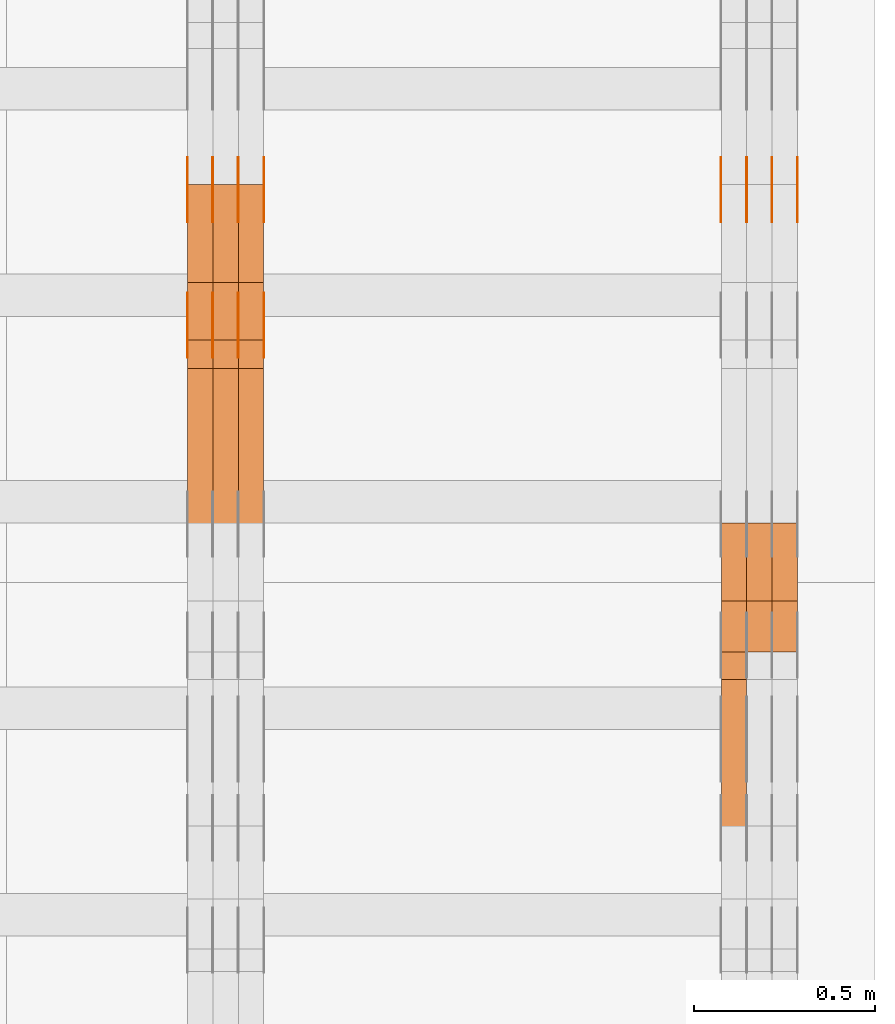
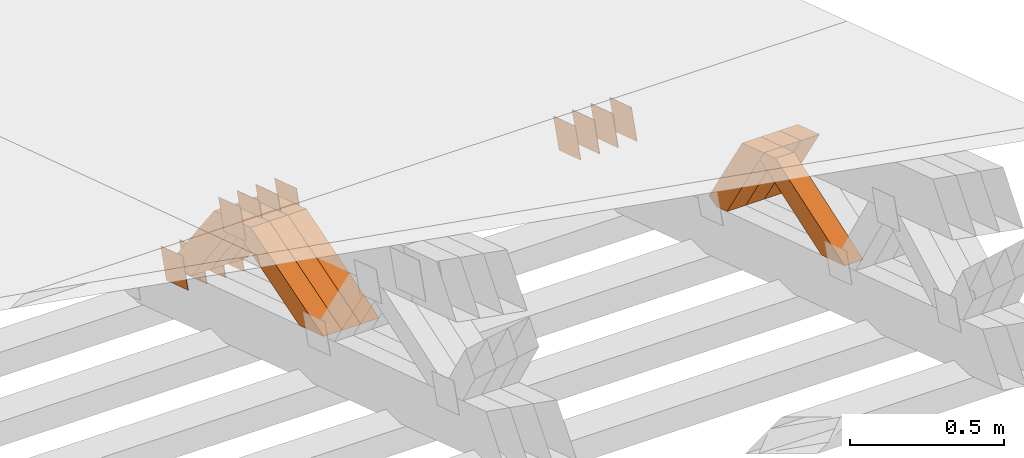
# One storey, part 368 of 385: 28 proxies.
"""IFC2X3 building model written with IfcOpenShell, lengths in millimetres."""

import ifcopenshell
import ifcopenshell.guid

model = None  # the IFC model being written
_history = None  # IfcOwnerHistory: only IFC2X3 demands one
_inside = {}  # id of a spatial element -> (the spatial element, [elements in it])
_under = {}  # id of a project, library or spatial element -> (it, [spatial elements below it])
_declared = {}  # id of a project -> (the project, [libraries it declares])
_typed = {}  # id of a type object -> (the type object, [elements of that type])
_made_of = {}  # id of a material, layer set ... -> (it, [elements and type objects made of it])


def new_model(schema):
    """Start an empty IFC model of exactly this schema.

    Asked for "IFC4X3", IfcOpenShell would pick the latest addendum, in which some entities
    have other attributes; the version numbers below select the first issue.
    IFC2X3 requires an IfcOwnerHistory on every rooted entity: one is made here for all.
    """
    global model, _history
    if schema == "IFC4X3":
        model = ifcopenshell.file(schema_version=(4, 3, 0, 0))
    else:
        model = ifcopenshell.file(schema=schema)
    _inside.clear()
    _under.clear()
    _declared.clear()
    _typed.clear()
    _made_of.clear()
    _history = None
    if model.schema == "IFC2X3":
        org = make("IfcOrganization", Name="unknown")
        user = make(
            "IfcPersonAndOrganization",
            ThePerson=make("IfcPerson", FamilyName="unknown"),
            TheOrganization=org,
        )
        app = make(
            "IfcApplication",
            ApplicationDeveloper=org,
            Version="unknown",
            ApplicationFullName="unknown",
            ApplicationIdentifier="unknown",
        )
        _history = make(
            "IfcOwnerHistory",
            OwningUser=user,
            OwningApplication=app,
            ChangeAction="ADDED",
            CreationDate=0,
        )
    return model


def make(cls, **values):
    """One entity of the class cls with the attributes given. An attribute that is None is left unset."""
    return model.create_entity(
        cls, **{name: value for name, value in values.items() if value is not None}
    )


def entity(cls, *values):
    """Any entity or typed value of the class cls, its attributes in the order of the schema. None: left unset."""
    e = model.create_entity(cls)
    for i, value in enumerate(values):
        if value is not None:
            e[i] = value
    return e


def rooted(cls, **values):
    """An entity with a GlobalId (a new one), such as an element, a storey or a relation."""
    return make(cls, GlobalId=ifcopenshell.guid.new(), OwnerHistory=_history, **values)


def si_unit(unit_type, name, prefix=None):
    """IfcSIUnit, for example si_unit("LENGTHUNIT", "METRE", prefix="MILLI")."""
    return make("IfcSIUnit", UnitType=unit_type, Prefix=prefix, Name=name)


def converted_unit(unit_type, name, factor, base, dimensions=None, offset=None):
    """IfcConversionBasedUnit, such as the inch: factor (a typed value) times the base unit."""
    return make(
        "IfcConversionBasedUnit"
        if offset is None
        else "IfcConversionBasedUnitWithOffset",
        ConversionOffset=offset,
        Dimensions=None
        if dimensions is None
        else entity("IfcDimensionalExponents", *dimensions),
        UnitType=unit_type,
        Name=name,
        ConversionFactor=make(
            "IfcMeasureWithUnit", ValueComponent=factor, UnitComponent=base
        ),
    )


def derived_unit(unit_type, elements):
    """IfcDerivedUnit: a product of units, each with its exponent."""
    return make(
        "IfcDerivedUnit",
        Elements=[
            make("IfcDerivedUnitElement", Unit=unit, Exponent=power)
            for unit, power in elements
        ],
        UnitType=unit_type,
    )


def assignment(units):
    """IfcUnitAssignment: the units of a project."""
    return None if units is None else make("IfcUnitAssignment", Units=units)


def point(xyz):
    """IfcCartesianPoint."""
    return None if xyz is None else make("IfcCartesianPoint", Coordinates=xyz)


def direction(xyz):
    """IfcDirection."""
    return None if xyz is None else make("IfcDirection", DirectionRatios=xyz)


def frame(location, z_axis=None, x_axis=None):
    """IfcAxis2Placement3D, a coordinate frame: its origin and axes. An axis left out is left unset."""
    return make(
        "IfcAxis2Placement3D",
        Location=point(location),
        Axis=direction(z_axis),
        RefDirection=direction(x_axis),
    )


def origin():
    """The frame at (0, 0, 0) with its axes left unset."""
    return frame((0.0, 0.0, 0.0))


def place(relative_to, where):
    """IfcLocalPlacement: puts the frame where relative to a parent placement (None: the world)."""
    return make(
        "IfcLocalPlacement", PlacementRelTo=relative_to, RelativePlacement=where
    )


def context(
    kind, dimensions, precision=None, world=None, true_north=None, identifier=None
):
    """IfcGeometricRepresentationContext, for example the 3D "Model" context."""
    return make(
        "IfcGeometricRepresentationContext",
        ContextIdentifier=identifier,
        ContextType=kind,
        CoordinateSpaceDimension=dimensions,
        Precision=precision,
        WorldCoordinateSystem=world,
        TrueNorth=true_north,
    )


def subcontext(parent, identifier, kind, view, scale=None):
    """IfcGeometricRepresentationSubContext, for example "Body" below "Model"."""
    return make(
        "IfcGeometricRepresentationSubContext",
        ContextIdentifier=identifier,
        ContextType=kind,
        ParentContext=parent,
        TargetScale=scale,
        TargetView=view,
    )


def project(units=None, contexts=None):
    """IfcProject with its units and contexts."""
    return rooted(
        "IfcProject",
        Name="project",
        RepresentationContexts=contexts,
        UnitsInContext=assignment(units),
    )


def spatial(cls, under=None, at=None, **own):
    """A site, building, storey or space (cls), placed at a placement, below another one or the project."""
    s = rooted(cls, ObjectPlacement=at, **own)
    if under is not None:
        _under.setdefault(under.id(), (under, []))[1].append(s)
    return s


def polyline(points):
    """IfcPolyline through the points."""
    return make("IfcPolyline", Points=[point(p) for p in points])


def outline(outer, holes=None, kind="AREA"):
    """IfcArbitraryClosedProfileDef: a profile drawn as a closed curve; with holes, ...WithVoids."""
    if holes is None:
        return make("IfcArbitraryClosedProfileDef", ProfileType=kind, OuterCurve=outer)
    return make(
        "IfcArbitraryProfileDefWithVoids",
        ProfileType=kind,
        OuterCurve=outer,
        InnerCurves=holes,
    )


def extrude(swept, where, along, depth):
    """IfcExtrudedAreaSolid: the profile swept, set in the frame where, extruded along a direction by depth."""
    return make(
        "IfcExtrudedAreaSolid",
        SweptArea=swept,
        Position=where,
        ExtrudedDirection=direction(along),
        Depth=depth,
    )


def shape(context_of_items, identifier, shape_type, items):
    """IfcShapeRepresentation: the items that make up one representation, for example the "Body"."""
    return make(
        "IfcShapeRepresentation",
        ContextOfItems=context_of_items,
        RepresentationIdentifier=identifier,
        RepresentationType=shape_type,
        Items=items,
    )


def source(mapping_origin, context_of_items, identifier, shape_type, items):
    """IfcRepresentationMap: a shape defined once, which mapped items show again and again."""
    return make(
        "IfcRepresentationMap",
        MappingOrigin=mapping_origin,
        MappedRepresentation=shape(context_of_items, identifier, shape_type, items),
    )


def transform(
    local_origin,
    x_axis=None,
    y_axis=None,
    z_axis=None,
    scale=None,
    scale2=None,
    scale3=None,
    uniform=True,
):
    """IfcCartesianTransformationOperator3D, or its non-uniform kind. x_axis, y_axis, z_axis: its Axis1, 2, 3."""
    if uniform:
        return make(
            "IfcCartesianTransformationOperator3D",
            Axis1=direction(x_axis),
            Axis2=direction(y_axis),
            LocalOrigin=point(local_origin),
            Scale=scale,
            Axis3=direction(z_axis),
        )
    return make(
        "IfcCartesianTransformationOperator3DnonUniform",
        Axis1=direction(x_axis),
        Axis2=direction(y_axis),
        LocalOrigin=point(local_origin),
        Scale=scale,
        Axis3=direction(z_axis),
        Scale2=scale2,
        Scale3=scale3,
    )


def mapped(mapping_source, mapping_target):
    """IfcMappedItem: shows the shape of a source again, moved by a transform."""
    return make(
        "IfcMappedItem", MappingSource=mapping_source, MappingTarget=mapping_target
    )


def material(Name=None, Category=None):
    """IfcMaterial."""
    return make("IfcMaterial", Name=Name, Category=Category)


def made_of(thing, what):
    """Note that an element or type object is made of a material, layer set ...; save() writes the relation."""
    if what is not None:
        _made_of.setdefault(what.id(), (what, []))[1].append(thing)
    return thing


def type_object(cls, material=None, **own):
    """A type object (cls), such as IfcWallType, which elements share."""
    return made_of(rooted(cls, **own), material)


def type_shapes(of_type, sources):
    """Give a type object the sources (RepresentationMaps) that its elements show as mapped items."""
    of_type.RepresentationMaps = sources


def element(
    cls,
    number,
    at=None,
    inside=None,
    cuts=None,
    type_object=None,
    material=None,
    context=None,
    identifier="Body",
    shape_type=None,
    held_by="IfcProductDefinitionShape",
    body=None,
    shapes=None,
    **own,
):
    """One element of the class cls, such as IfcWall. Its Tag is "e" and its number.

    at: its placement. inside: the storey or other place that contains it. cuts: it is an
    opening in that element (IfcRelVoidsElement). A single representation is given by context,
    identifier, shape_type and body (its items); several are given by shapes. held_by: the class
    of the entity that holds the representations. save() writes the other relations.
    """
    e = rooted(cls, Tag="e%d" % number, ObjectPlacement=at, **own)
    if body is not None:
        shapes = [shape(context, identifier, shape_type, body)]
    if shapes is not None:
        e.Representation = make(held_by, Representations=shapes)
    if inside is not None:
        _inside.setdefault(inside.id(), (inside, []))[1].append(e)
    if cuts is not None:
        rooted(
            "IfcRelVoidsElement", RelatingBuildingElement=cuts, RelatedOpeningElement=e
        )
    if type_object is not None:
        _typed.setdefault(type_object.id(), (type_object, []))[1].append(e)
    return made_of(e, material)


def aggregate(whole, parts):
    """IfcRelAggregates: a whole, such as a stair, and the parts it consists of."""
    return rooted("IfcRelAggregates", RelatingObject=whole, RelatedObjects=parts)


def save(model, path):
    """Write the relations noted so far, then the file.

    IfcRelAggregates (storeys below a building ...), IfcRelContainedInSpatialStructure (elements
    in a storey), IfcRelDefinesByType, IfcRelAssociatesMaterial and IfcRelDeclares: one each for
    every whole, place, type object, material and project.
    """
    for whole, parts in _under.values():
        aggregate(whole, parts)
    for where, things in _inside.values():
        rooted(
            "IfcRelContainedInSpatialStructure",
            RelatedElements=things,
            RelatingStructure=where,
        )
    for kind, things in _typed.values():
        rooted("IfcRelDefinesByType", RelatedObjects=things, RelatingType=kind)
    for what, things in _made_of.values():
        rooted("IfcRelAssociatesMaterial", RelatedObjects=things, RelatingMaterial=what)
    for by, libraries in _declared.values():
        rooted("IfcRelDeclares", RelatingContext=by, RelatedDefinitions=libraries)
    model.write(path)


model = new_model("IFC2X3")

# Units and contexts
model_context = context("Model", 3, precision=0.01, world=origin(), true_north=direction((6.12303176911189e-17, 1.0)))
body_context = subcontext(model_context, "Body", "Model", "MODEL_VIEW")
ifc_project = project(units=[si_unit("LENGTHUNIT", "METRE", prefix="MILLI"), si_unit("AREAUNIT", "SQUARE_METRE"), si_unit("VOLUMEUNIT", "CUBIC_METRE"), converted_unit("PLANEANGLEUNIT", "DEGREE", entity("IfcRatioMeasure", 0.0174532925199433), si_unit("PLANEANGLEUNIT", "RADIAN"), dimensions=[0, 0, 0, 0, 0, 0, 0]), si_unit("MASSUNIT", "GRAM", prefix="KILO"), derived_unit("MASSDENSITYUNIT", [(si_unit("MASSUNIT", "GRAM", prefix="KILO"), 1), (si_unit("LENGTHUNIT", "METRE"), -3)]), si_unit("TIMEUNIT", "SECOND"), si_unit("FREQUENCYUNIT", "HERTZ"), si_unit("THERMODYNAMICTEMPERATUREUNIT", "DEGREE_CELSIUS"), derived_unit("THERMALTRANSMITTANCEUNIT", [(si_unit("MASSUNIT", "GRAM", prefix="KILO"), 1), (si_unit("THERMODYNAMICTEMPERATUREUNIT", "KELVIN"), -1), (si_unit("TIMEUNIT", "SECOND"), -3)]), derived_unit("VOLUMETRICFLOWRATEUNIT", [(si_unit("LENGTHUNIT", "METRE"), 3), (si_unit("TIMEUNIT", "SECOND"), -1)]), si_unit("ELECTRICCURRENTUNIT", "AMPERE"), si_unit("ELECTRICVOLTAGEUNIT", "VOLT"), si_unit("POWERUNIT", "WATT"), si_unit("FORCEUNIT", "NEWTON", prefix="KILO"), si_unit("ILLUMINANCEUNIT", "LUX"), si_unit("LUMINOUSFLUXUNIT", "LUMEN"), si_unit("LUMINOUSINTENSITYUNIT", "CANDELA"), derived_unit("USERDEFINED", [(si_unit("MASSUNIT", "GRAM", prefix="KILO"), -1), (si_unit("LENGTHUNIT", "METRE"), -2), (si_unit("TIMEUNIT", "SECOND"), 3), (si_unit("LUMINOUSFLUXUNIT", "LUMEN"), 1)]), derived_unit("LINEARVELOCITYUNIT", [(si_unit("LENGTHUNIT", "METRE"), 1), (si_unit("TIMEUNIT", "SECOND"), -1)]), si_unit("PRESSUREUNIT", "PASCAL"), derived_unit("USERDEFINED", [(si_unit("LENGTHUNIT", "METRE"), -2), (si_unit("MASSUNIT", "GRAM", prefix="KILO"), 1), (si_unit("TIMEUNIT", "SECOND"), -2)])], contexts=[model_context])

# Site, building, storey
site_placement = place(None, origin())
site = spatial("IfcSite", under=ifc_project, at=site_placement, CompositionType="ELEMENT")
building_placement = place(site_placement, origin())
building = spatial("IfcBuilding", under=site, at=building_placement, CompositionType="ELEMENT")
storey_placement = place(building_placement, origin())
storey = spatial("IfcBuildingStorey", under=building, at=storey_placement, Name="Default", CompositionType="ELEMENT", Elevation=0.0)

# Proxies
ifc_material_1 = material(Name="IfcSurfaceStyle #616510")
building_element_proxy_type_1 = type_object("IfcBuildingElementProxyType", PredefinedType="NOTDEFINED", material=ifc_material_1)
shared_shape_1 = source(origin(), body_context, "Body", "SweptSolid", [
    extrude(outline(polyline([(-75.0001116115454, -60.0000599592451), (75.0000887592496, -60.0000599592451), (75.0001116115454, 60.0000599592451), (-75.0000887592496, 60.0000599592451), (-75.0001116115454, -60.0000599592451)])), frame((75.0001116115454, 60.0000599592451, 0.0), z_axis=(0.0, 0.0, 1.0), x_axis=(-1.0, 0.0, 0.0)), (0.0, 0.0, 1.0), 1.3),
])
type_shapes(building_element_proxy_type_1, [shared_shape_1])
proxy_1_placement = place(building_placement, frame((49861.3, 21881.0815195707, 1532.2522473242), z_axis=(-1.0, 0.0, 0.0), x_axis=(0.0, -0.951056516295124, 0.309016994375039)))
element("IfcBuildingElementProxy", 1, at=proxy_1_placement, inside=storey, type_object=building_element_proxy_type_1, material=ifc_material_1, context=body_context, shape_type="MappedRepresentation", body=[
    mapped(shared_shape_1, transform((0.0, 0.0, 0.0), scale=1.0)),
])
ifc_material_2 = material(Name="IfcSurfaceStyle #616453")
building_element_proxy_type_2 = type_object("IfcBuildingElementProxyType", PredefinedType="NOTDEFINED", material=ifc_material_2)
shared_shape_2 = source(origin(), body_context, "Body", "SweptSolid", [
    extrude(outline(polyline([(-75.0001116115454, -60.0000599592451), (75.0000887592496, -60.0000599592451), (75.0001116115454, 60.0000599592451), (-75.0000887592496, 60.0000599592451), (-75.0001116115454, -60.0000599592451)])), frame((75.0001116115454, 60.0000599592451, 0.0), z_axis=(0.0, 0.0, 1.0), x_axis=(-1.0, 0.0, 0.0)), (0.0, 0.0, 1.0), 1.3),
])
type_shapes(building_element_proxy_type_2, [shared_shape_2])
proxy_2_placement = place(building_placement, frame((49790.0, 21881.0815195707, 1532.2522473242), z_axis=(-1.0, 0.0, 0.0), x_axis=(0.0, -0.951056516295124, 0.309016994375039)))
element("IfcBuildingElementProxy", 2, at=proxy_2_placement, inside=storey, type_object=building_element_proxy_type_2, material=ifc_material_2, context=body_context, shape_type="MappedRepresentation", body=[
    mapped(shared_shape_2, transform((0.0, 0.0, 0.0), scale=1.0)),
])
ifc_material_3 = material(Name="IfcSurfaceStyle #616396")
building_element_proxy_type_3 = type_object("IfcBuildingElementProxyType", PredefinedType="NOTDEFINED", material=ifc_material_3)
shared_shape_3 = source(origin(), body_context, "Body", "SweptSolid", [
    extrude(outline(polyline([(-75.0001116115454, -60.0000599592451), (75.0000887592496, -60.0000599592451), (75.0001116115454, 60.0000599592451), (-75.0000887592496, 60.0000599592451), (-75.0001116115454, -60.0000599592451)])), frame((75.0001116115454, 60.0000599592451, 0.0), z_axis=(0.0, 0.0, 1.0), x_axis=(-1.0, 0.0, 0.0)), (0.0, 0.0, 1.0), 1.3),
])
type_shapes(building_element_proxy_type_3, [shared_shape_3])
proxy_3_placement = place(building_placement, frame((49791.3, 21881.0815195707, 1532.2522473242), z_axis=(-1.0, 0.0, 0.0), x_axis=(0.0, -0.951056516295124, 0.309016994375039)))
element("IfcBuildingElementProxy", 3, at=proxy_3_placement, inside=storey, type_object=building_element_proxy_type_3, material=ifc_material_3, context=body_context, shape_type="MappedRepresentation", body=[
    mapped(shared_shape_3, transform((0.0, 0.0, 0.0), scale=1.0)),
])
ifc_material_4 = material(Name="IfcSurfaceStyle #616339")
building_element_proxy_type_4 = type_object("IfcBuildingElementProxyType", PredefinedType="NOTDEFINED", material=ifc_material_4)
shared_shape_4 = source(origin(), body_context, "Body", "SweptSolid", [
    extrude(outline(polyline([(-75.0001116115454, -60.0000599592451), (75.0000887592496, -60.0000599592451), (75.0001116115454, 60.0000599592451), (-75.0000887592496, 60.0000599592451), (-75.0001116115454, -60.0000599592451)])), frame((75.0001116115454, 60.0000599592451, 0.0), z_axis=(0.0, 0.0, 1.0), x_axis=(-1.0, 0.0, 0.0)), (0.0, 0.0, 1.0), 1.29999999999999),
])
type_shapes(building_element_proxy_type_4, [shared_shape_4])
proxy_4_placement = place(building_placement, frame((49720.0, 21881.0815195707, 1532.2522473242), z_axis=(-1.0, 0.0, 0.0), x_axis=(0.0, -0.951056516295124, 0.309016994375039)))
element("IfcBuildingElementProxy", 4, at=proxy_4_placement, inside=storey, type_object=building_element_proxy_type_4, material=ifc_material_4, context=body_context, shape_type="MappedRepresentation", body=[
    mapped(shared_shape_4, transform((0.0, 0.0, 0.0), scale=1.0)),
])
ifc_material_5 = material(Name="IfcSurfaceStyle #616282")
building_element_proxy_type_5 = type_object("IfcBuildingElementProxyType", PredefinedType="NOTDEFINED", material=ifc_material_5)
shared_shape_5 = source(origin(), body_context, "Body", "SweptSolid", [
    extrude(outline(polyline([(-75.0001116115454, -60.0000599592451), (75.0000887592496, -60.0000599592451), (75.0001116115454, 60.0000599592451), (-75.0000887592496, 60.0000599592451), (-75.0001116115454, -60.0000599592451)])), frame((75.0001116115454, 60.0000599592451, 0.0), z_axis=(0.0, 0.0, 1.0), x_axis=(-1.0, 0.0, 0.0)), (0.0, 0.0, 1.0), 1.29999999999999),
])
type_shapes(building_element_proxy_type_5, [shared_shape_5])
proxy_5_placement = place(building_placement, frame((49721.3, 21881.0815195707, 1532.2522473242), z_axis=(-1.0, 0.0, 0.0), x_axis=(0.0, -0.951056516295124, 0.309016994375039)))
element("IfcBuildingElementProxy", 5, at=proxy_5_placement, inside=storey, type_object=building_element_proxy_type_5, material=ifc_material_5, context=body_context, shape_type="MappedRepresentation", body=[
    mapped(shared_shape_5, transform((0.0, 0.0, 0.0), scale=1.0)),
])
ifc_material_6 = material(Name="IfcSurfaceStyle #616225")
building_element_proxy_type_6 = type_object("IfcBuildingElementProxyType", PredefinedType="NOTDEFINED", material=ifc_material_6)
shared_shape_6 = source(origin(), body_context, "Body", "SweptSolid", [
    extrude(outline(polyline([(-75.0001116115454, -60.0000599592451), (75.0000887592496, -60.0000599592451), (75.0001116115454, 60.0000599592451), (-75.0000887592496, 60.0000599592451), (-75.0001116115454, -60.0000599592451)])), frame((75.0001116115454, 60.0000599592451, 0.0), z_axis=(0.0, 0.0, 1.0), x_axis=(-1.0, 0.0, 0.0)), (0.0, 0.0, 1.0), 1.29999999999999),
])
type_shapes(building_element_proxy_type_6, [shared_shape_6])
proxy_6_placement = place(building_placement, frame((49650.0, 21881.0815195707, 1532.2522473242), z_axis=(-1.0, 0.0, 0.0), x_axis=(0.0, -0.951056516295124, 0.309016994375039)))
element("IfcBuildingElementProxy", 6, at=proxy_6_placement, inside=storey, type_object=building_element_proxy_type_6, material=ifc_material_6, context=body_context, shape_type="MappedRepresentation", body=[
    mapped(shared_shape_6, transform((0.0, 0.0, 0.0), scale=1.0)),
])
ifc_material_7 = material(Name="IfcSurfaceStyle #599458")
building_element_proxy_type_7 = type_object("IfcBuildingElementProxyType", Name="T2-W26 599456", PredefinedType="NOTDEFINED", material=ifc_material_7)
shared_shape_7 = source(origin(), body_context, "Body", "SweptSolid", [
    extrude(outline(polyline([(-339.390941716546, -47.5001331548025), (137.738864791781, -47.5001331548025), (201.272298560955, 6.02772073885038e-05), (212.703852542003, 47.5001030161988), (-212.324074178193, 47.5001030161988), (-339.390941716546, -47.5001331548025)])), frame((212.703852542003, 47.5001030161988, 0.0), z_axis=(0.0, 0.0, 1.0), x_axis=(-1.0, 0.0, 0.0)), (0.0, 0.0, 1.0), 70.0),
])
type_shapes(building_element_proxy_type_7, [shared_shape_7])
proxy_7_placement = place(building_placement, frame((49720.0, 20576.541015625, 2286.80981445313), z_axis=(-1.0, 0.0, 0.0), x_axis=(0.0, -0.946743816465327, -0.321987804093053)))
element("IfcBuildingElementProxy", 7, at=proxy_7_placement, inside=storey, type_object=building_element_proxy_type_7, material=ifc_material_7, Name="T2-W26", context=body_context, shape_type="MappedRepresentation", body=[
    mapped(shared_shape_7, transform((0.0, 0.0, 0.0), scale=1.0)),
])
ifc_material_8 = material(Name="IfcSurfaceStyle #599194")
building_element_proxy_type_8 = type_object("IfcBuildingElementProxyType", Name="T2-W29 599192", PredefinedType="NOTDEFINED", material=ifc_material_8)
shared_shape_8 = source(origin(), body_context, "Body", "SweptSolid", [
    extrude(outline(polyline([(-202.325994317059, -47.5000867467013), (200.714255560873, -47.5000867467013), (187.834128885383, 0.000593513395139059), (130.590899902046, 47.4997899900038), (-316.813290031243, 47.4997899900038), (-202.325994317059, -47.5000867467013)])), frame((200.714255560873, 47.5001935424745, 0.0), z_axis=(0.0, 0.0, 1.0), x_axis=(-1.0, 0.0, 0.0)), (0.0, 0.0, 1.0), 70.0),
])
type_shapes(building_element_proxy_type_8, [shared_shape_8])
proxy_8_placement = place(building_placement, frame((49860.0, 20827.0771193222, 1890.72342063252), z_axis=(-1.0, 0.0, 0.0), x_axis=(0.0, -0.534567451138397, 0.845125813227473)))
element("IfcBuildingElementProxy", 8, at=proxy_8_placement, inside=storey, type_object=building_element_proxy_type_8, material=ifc_material_8, Name="T2-W29", context=body_context, shape_type="MappedRepresentation", body=[
    mapped(shared_shape_8, transform((0.0, 0.0, 0.0), scale=1.0)),
])
ifc_material_9 = material(Name="IfcSurfaceStyle #599128")
building_element_proxy_type_9 = type_object("IfcBuildingElementProxyType", Name="T2-W29 599126", PredefinedType="NOTDEFINED", material=ifc_material_9)
shared_shape_9 = source(origin(), body_context, "Body", "SweptSolid", [
    extrude(outline(polyline([(-202.325994317059, -47.5000867467013), (200.714255560873, -47.5000867467013), (187.834128885383, 0.000593513395139059), (130.590899902046, 47.4997899900038), (-316.813290031243, 47.4997899900038), (-202.325994317059, -47.5000867467013)])), frame((200.714255560873, 47.5001935424745, 0.0), z_axis=(0.0, 0.0, 1.0), x_axis=(-1.0, 0.0, 0.0)), (0.0, 0.0, 1.0), 70.0),
])
type_shapes(building_element_proxy_type_9, [shared_shape_9])
proxy_9_placement = place(building_placement, frame((49790.0, 20827.0771193222, 1890.72342063252), z_axis=(-1.0, 0.0, 0.0), x_axis=(0.0, -0.534567451138397, 0.845125813227473)))
element("IfcBuildingElementProxy", 9, at=proxy_9_placement, inside=storey, type_object=building_element_proxy_type_9, material=ifc_material_9, Name="T2-W29", context=body_context, shape_type="MappedRepresentation", body=[
    mapped(shared_shape_9, transform((0.0, 0.0, 0.0), scale=1.0)),
])
ifc_material_10 = material(Name="IfcSurfaceStyle #599062")
building_element_proxy_type_10 = type_object("IfcBuildingElementProxyType", Name="T2-W29 599060", PredefinedType="NOTDEFINED", material=ifc_material_10)
shared_shape_10 = source(origin(), body_context, "Body", "SweptSolid", [
    extrude(outline(polyline([(-202.325994317059, -47.5000867467013), (200.714255560873, -47.5000867467013), (187.834128885383, 0.000593513395139059), (130.590899902046, 47.4997899900038), (-316.813290031243, 47.4997899900038), (-202.325994317059, -47.5000867467013)])), frame((200.714255560873, 47.5001935424745, 0.0), z_axis=(0.0, 0.0, 1.0), x_axis=(-1.0, 0.0, 0.0)), (0.0, 0.0, 1.0), 70.0),
])
type_shapes(building_element_proxy_type_10, [shared_shape_10])
proxy_10_placement = place(building_placement, frame((49720.0, 20827.0771193222, 1890.72342063252), z_axis=(-1.0, 0.0, 0.0), x_axis=(0.0, -0.534567451138397, 0.845125813227473)))
element("IfcBuildingElementProxy", 10, at=proxy_10_placement, inside=storey, type_object=building_element_proxy_type_10, material=ifc_material_10, Name="T2-W29", context=body_context, shape_type="MappedRepresentation", body=[
    mapped(shared_shape_10, transform((0.0, 0.0, 0.0), scale=1.0)),
])
ifc_material_11 = material(Name="IfcSurfaceStyle #582078")
building_element_proxy_type_11 = type_object("IfcBuildingElementProxyType", PredefinedType="NOTDEFINED", material=ifc_material_11)
shared_shape_11 = source(origin(), body_context, "Body", "SweptSolid", [
    extrude(outline(polyline([(-75.0001116115454, -60.0000599592451), (75.0000887592496, -60.0000599592451), (75.0001116115454, 60.0000599592451), (-75.0000887592496, 60.0000599592451), (-75.0001116115454, -60.0000599592451)])), frame((75.0001116115454, 60.0000599592451, 0.0), z_axis=(0.0, 0.0, 1.0), x_axis=(-1.0, 0.0, 0.0)), (0.0, 0.0, 1.0), 1.3),
])
type_shapes(building_element_proxy_type_11, [shared_shape_11])
proxy_11_placement = place(building_placement, frame((48386.3, 21881.0815195707, 1532.2522473242), z_axis=(-1.0, 0.0, 0.0), x_axis=(0.0, -0.951056516295124, 0.309016994375039)))
element("IfcBuildingElementProxy", 11, at=proxy_11_placement, inside=storey, type_object=building_element_proxy_type_11, material=ifc_material_11, context=body_context, shape_type="MappedRepresentation", body=[
    mapped(shared_shape_11, transform((0.0, 0.0, 0.0), scale=1.0)),
])
ifc_material_12 = material(Name="IfcSurfaceStyle #582021")
building_element_proxy_type_12 = type_object("IfcBuildingElementProxyType", PredefinedType="NOTDEFINED", material=ifc_material_12)
shared_shape_12 = source(origin(), body_context, "Body", "SweptSolid", [
    extrude(outline(polyline([(-75.0001116115454, -60.0000599592451), (75.0000887592496, -60.0000599592451), (75.0001116115454, 60.0000599592451), (-75.0000887592496, 60.0000599592451), (-75.0001116115454, -60.0000599592451)])), frame((75.0001116115454, 60.0000599592451, 0.0), z_axis=(0.0, 0.0, 1.0), x_axis=(-1.0, 0.0, 0.0)), (0.0, 0.0, 1.0), 1.3),
])
type_shapes(building_element_proxy_type_12, [shared_shape_12])
proxy_12_placement = place(building_placement, frame((48315.0, 21881.0815195707, 1532.2522473242), z_axis=(-1.0, 0.0, 0.0), x_axis=(0.0, -0.951056516295124, 0.309016994375039)))
element("IfcBuildingElementProxy", 12, at=proxy_12_placement, inside=storey, type_object=building_element_proxy_type_12, material=ifc_material_12, context=body_context, shape_type="MappedRepresentation", body=[
    mapped(shared_shape_12, transform((0.0, 0.0, 0.0), scale=1.0)),
])
ifc_material_13 = material(Name="IfcSurfaceStyle #581964")
building_element_proxy_type_13 = type_object("IfcBuildingElementProxyType", PredefinedType="NOTDEFINED", material=ifc_material_13)
shared_shape_13 = source(origin(), body_context, "Body", "SweptSolid", [
    extrude(outline(polyline([(-75.0001116115454, -60.0000599592451), (75.0000887592496, -60.0000599592451), (75.0001116115454, 60.0000599592451), (-75.0000887592496, 60.0000599592451), (-75.0001116115454, -60.0000599592451)])), frame((75.0001116115454, 60.0000599592451, 0.0), z_axis=(0.0, 0.0, 1.0), x_axis=(-1.0, 0.0, 0.0)), (0.0, 0.0, 1.0), 1.3),
])
type_shapes(building_element_proxy_type_13, [shared_shape_13])
proxy_13_placement = place(building_placement, frame((48316.3, 21881.0815195707, 1532.2522473242), z_axis=(-1.0, 0.0, 0.0), x_axis=(0.0, -0.951056516295124, 0.309016994375039)))
element("IfcBuildingElementProxy", 13, at=proxy_13_placement, inside=storey, type_object=building_element_proxy_type_13, material=ifc_material_13, context=body_context, shape_type="MappedRepresentation", body=[
    mapped(shared_shape_13, transform((0.0, 0.0, 0.0), scale=1.0)),
])
ifc_material_14 = material(Name="IfcSurfaceStyle #581907")
building_element_proxy_type_14 = type_object("IfcBuildingElementProxyType", PredefinedType="NOTDEFINED", material=ifc_material_14)
shared_shape_14 = source(origin(), body_context, "Body", "SweptSolid", [
    extrude(outline(polyline([(-75.0001116115454, -60.0000599592451), (75.0000887592496, -60.0000599592451), (75.0001116115454, 60.0000599592451), (-75.0000887592496, 60.0000599592451), (-75.0001116115454, -60.0000599592451)])), frame((75.0001116115454, 60.0000599592451, 0.0), z_axis=(0.0, 0.0, 1.0), x_axis=(-1.0, 0.0, 0.0)), (0.0, 0.0, 1.0), 1.29999999999999),
])
type_shapes(building_element_proxy_type_14, [shared_shape_14])
proxy_14_placement = place(building_placement, frame((48245.0, 21881.0815195707, 1532.2522473242), z_axis=(-1.0, 0.0, 0.0), x_axis=(0.0, -0.951056516295124, 0.309016994375039)))
element("IfcBuildingElementProxy", 14, at=proxy_14_placement, inside=storey, type_object=building_element_proxy_type_14, material=ifc_material_14, context=body_context, shape_type="MappedRepresentation", body=[
    mapped(shared_shape_14, transform((0.0, 0.0, 0.0), scale=1.0)),
])
ifc_material_15 = material(Name="IfcSurfaceStyle #581850")
building_element_proxy_type_15 = type_object("IfcBuildingElementProxyType", PredefinedType="NOTDEFINED", material=ifc_material_15)
shared_shape_15 = source(origin(), body_context, "Body", "SweptSolid", [
    extrude(outline(polyline([(-75.0001116115454, -60.0000599592451), (75.0000887592496, -60.0000599592451), (75.0001116115454, 60.0000599592451), (-75.0000887592496, 60.0000599592451), (-75.0001116115454, -60.0000599592451)])), frame((75.0001116115454, 60.0000599592451, 0.0), z_axis=(0.0, 0.0, 1.0), x_axis=(-1.0, 0.0, 0.0)), (0.0, 0.0, 1.0), 1.29999999999999),
])
type_shapes(building_element_proxy_type_15, [shared_shape_15])
proxy_15_placement = place(building_placement, frame((48246.3, 21881.0815195707, 1532.2522473242), z_axis=(-1.0, 0.0, 0.0), x_axis=(0.0, -0.951056516295124, 0.309016994375039)))
element("IfcBuildingElementProxy", 15, at=proxy_15_placement, inside=storey, type_object=building_element_proxy_type_15, material=ifc_material_15, context=body_context, shape_type="MappedRepresentation", body=[
    mapped(shared_shape_15, transform((0.0, 0.0, 0.0), scale=1.0)),
])
ifc_material_16 = material(Name="IfcSurfaceStyle #581793")
building_element_proxy_type_16 = type_object("IfcBuildingElementProxyType", PredefinedType="NOTDEFINED", material=ifc_material_16)
shared_shape_16 = source(origin(), body_context, "Body", "SweptSolid", [
    extrude(outline(polyline([(-75.0001116115454, -60.0000599592451), (75.0000887592496, -60.0000599592451), (75.0001116115454, 60.0000599592451), (-75.0000887592496, 60.0000599592451), (-75.0001116115454, -60.0000599592451)])), frame((75.0001116115454, 60.0000599592451, 0.0), z_axis=(0.0, 0.0, 1.0), x_axis=(-1.0, 0.0, 0.0)), (0.0, 0.0, 1.0), 1.29999999999999),
])
type_shapes(building_element_proxy_type_16, [shared_shape_16])
proxy_16_placement = place(building_placement, frame((48175.0, 21881.0815195707, 1532.2522473242), z_axis=(-1.0, 0.0, 0.0), x_axis=(0.0, -0.951056516295124, 0.309016994375039)))
element("IfcBuildingElementProxy", 16, at=proxy_16_placement, inside=storey, type_object=building_element_proxy_type_16, material=ifc_material_16, context=body_context, shape_type="MappedRepresentation", body=[
    mapped(shared_shape_16, transform((0.0, 0.0, 0.0), scale=1.0)),
])
ifc_material_17 = material(Name="IfcSurfaceStyle #576606")
building_element_proxy_type_17 = type_object("IfcBuildingElementProxyType", PredefinedType="NOTDEFINED", material=ifc_material_17)
shared_shape_17 = source(origin(), body_context, "Body", "SweptSolid", [
    extrude(outline(polyline([(-74.9998794200064, -59.9999845156358), (74.9998565677224, -59.9999845156358), (74.9998794200064, 59.9999845156358), (-74.9998565677224, 59.9999845156358), (-74.9998794200064, -59.9999845156358)])), frame((74.9999765995044, 60.0000596852337, 0.0), z_axis=(0.0, 0.0, 1.0), x_axis=(-1.0, 0.0, 0.0)), (0.0, 0.0, 1.0), 1.3),
])
type_shapes(building_element_proxy_type_17, [shared_shape_17])
proxy_17_placement = place(building_placement, frame((48386.3, 21505.9776314857, 1954.5332951652), z_axis=(-1.0, 0.0, 0.0), x_axis=(0.0, -0.951056516295154, 0.309016994374948)))
element("IfcBuildingElementProxy", 17, at=proxy_17_placement, inside=storey, type_object=building_element_proxy_type_17, material=ifc_material_17, context=body_context, shape_type="MappedRepresentation", body=[
    mapped(shared_shape_17, transform((0.0, 0.0, 0.0), scale=1.0)),
])
ifc_material_18 = material(Name="IfcSurfaceStyle #576549")
building_element_proxy_type_18 = type_object("IfcBuildingElementProxyType", PredefinedType="NOTDEFINED", material=ifc_material_18)
shared_shape_18 = source(origin(), body_context, "Body", "SweptSolid", [
    extrude(outline(polyline([(-74.9998794200064, -59.9999845156358), (74.9998565677224, -59.9999845156358), (74.9998794200064, 59.9999845156358), (-74.9998565677224, 59.9999845156358), (-74.9998794200064, -59.9999845156358)])), frame((74.9999765995044, 60.0000596852337, 0.0), z_axis=(0.0, 0.0, 1.0), x_axis=(-1.0, 0.0, 0.0)), (0.0, 0.0, 1.0), 1.3),
])
type_shapes(building_element_proxy_type_18, [shared_shape_18])
proxy_18_placement = place(building_placement, frame((48315.0, 21505.9776314857, 1954.5332951652), z_axis=(-1.0, 0.0, 0.0), x_axis=(0.0, -0.951056516295154, 0.309016994374948)))
element("IfcBuildingElementProxy", 18, at=proxy_18_placement, inside=storey, type_object=building_element_proxy_type_18, material=ifc_material_18, context=body_context, shape_type="MappedRepresentation", body=[
    mapped(shared_shape_18, transform((0.0, 0.0, 0.0), scale=1.0)),
])
ifc_material_19 = material(Name="IfcSurfaceStyle #576492")
building_element_proxy_type_19 = type_object("IfcBuildingElementProxyType", PredefinedType="NOTDEFINED", material=ifc_material_19)
shared_shape_19 = source(origin(), body_context, "Body", "SweptSolid", [
    extrude(outline(polyline([(-74.9998794200064, -59.9999845156358), (74.9998565677224, -59.9999845156358), (74.9998794200064, 59.9999845156358), (-74.9998565677224, 59.9999845156358), (-74.9998794200064, -59.9999845156358)])), frame((74.9999765995044, 60.0000596852337, 0.0), z_axis=(0.0, 0.0, 1.0), x_axis=(-1.0, 0.0, 0.0)), (0.0, 0.0, 1.0), 1.3),
])
type_shapes(building_element_proxy_type_19, [shared_shape_19])
proxy_19_placement = place(building_placement, frame((48316.3, 21505.9776314857, 1954.5332951652), z_axis=(-1.0, 0.0, 0.0), x_axis=(0.0, -0.951056516295154, 0.309016994374948)))
element("IfcBuildingElementProxy", 19, at=proxy_19_placement, inside=storey, type_object=building_element_proxy_type_19, material=ifc_material_19, context=body_context, shape_type="MappedRepresentation", body=[
    mapped(shared_shape_19, transform((0.0, 0.0, 0.0), scale=1.0)),
])
ifc_material_20 = material(Name="IfcSurfaceStyle #576435")
building_element_proxy_type_20 = type_object("IfcBuildingElementProxyType", PredefinedType="NOTDEFINED", material=ifc_material_20)
shared_shape_20 = source(origin(), body_context, "Body", "SweptSolid", [
    extrude(outline(polyline([(-74.9998794200064, -59.9999845156358), (74.9998565677224, -59.9999845156358), (74.9998794200064, 59.9999845156358), (-74.9998565677224, 59.9999845156358), (-74.9998794200064, -59.9999845156358)])), frame((74.9999765995044, 60.0000596852337, 0.0), z_axis=(0.0, 0.0, 1.0), x_axis=(-1.0, 0.0, 0.0)), (0.0, 0.0, 1.0), 1.29999999999999),
])
type_shapes(building_element_proxy_type_20, [shared_shape_20])
proxy_20_placement = place(building_placement, frame((48245.0, 21505.9776314857, 1954.5332951652), z_axis=(-1.0, 0.0, 0.0), x_axis=(0.0, -0.951056516295154, 0.309016994374948)))
element("IfcBuildingElementProxy", 20, at=proxy_20_placement, inside=storey, type_object=building_element_proxy_type_20, material=ifc_material_20, context=body_context, shape_type="MappedRepresentation", body=[
    mapped(shared_shape_20, transform((0.0, 0.0, 0.0), scale=1.0)),
])
ifc_material_21 = material(Name="IfcSurfaceStyle #576378")
building_element_proxy_type_21 = type_object("IfcBuildingElementProxyType", PredefinedType="NOTDEFINED", material=ifc_material_21)
shared_shape_21 = source(origin(), body_context, "Body", "SweptSolid", [
    extrude(outline(polyline([(-74.9998794200064, -59.9999845156358), (74.9998565677224, -59.9999845156358), (74.9998794200064, 59.9999845156358), (-74.9998565677224, 59.9999845156358), (-74.9998794200064, -59.9999845156358)])), frame((74.9999765995044, 60.0000596852337, 0.0), z_axis=(0.0, 0.0, 1.0), x_axis=(-1.0, 0.0, 0.0)), (0.0, 0.0, 1.0), 1.29999999999999),
])
type_shapes(building_element_proxy_type_21, [shared_shape_21])
proxy_21_placement = place(building_placement, frame((48246.3, 21505.9776314857, 1954.5332951652), z_axis=(-1.0, 0.0, 0.0), x_axis=(0.0, -0.951056516295154, 0.309016994374948)))
element("IfcBuildingElementProxy", 21, at=proxy_21_placement, inside=storey, type_object=building_element_proxy_type_21, material=ifc_material_21, context=body_context, shape_type="MappedRepresentation", body=[
    mapped(shared_shape_21, transform((0.0, 0.0, 0.0), scale=1.0)),
])
ifc_material_22 = material(Name="IfcSurfaceStyle #576321")
building_element_proxy_type_22 = type_object("IfcBuildingElementProxyType", PredefinedType="NOTDEFINED", material=ifc_material_22)
shared_shape_22 = source(origin(), body_context, "Body", "SweptSolid", [
    extrude(outline(polyline([(-74.9998794200064, -59.9999845156358), (74.9998565677224, -59.9999845156358), (74.9998794200064, 59.9999845156358), (-74.9998565677224, 59.9999845156358), (-74.9998794200064, -59.9999845156358)])), frame((74.9999765995044, 60.0000596852337, 0.0), z_axis=(0.0, 0.0, 1.0), x_axis=(-1.0, 0.0, 0.0)), (0.0, 0.0, 1.0), 1.29999999999999),
])
type_shapes(building_element_proxy_type_22, [shared_shape_22])
proxy_22_placement = place(building_placement, frame((48175.0, 21505.9776314857, 1954.5332951652), z_axis=(-1.0, 0.0, 0.0), x_axis=(0.0, -0.951056516295154, 0.309016994374948)))
element("IfcBuildingElementProxy", 22, at=proxy_22_placement, inside=storey, type_object=building_element_proxy_type_22, material=ifc_material_22, context=body_context, shape_type="MappedRepresentation", body=[
    mapped(shared_shape_22, transform((0.0, 0.0, 0.0), scale=1.0)),
])
ifc_material_23 = material(Name="IfcSurfaceStyle #564366")
building_element_proxy_type_23 = type_object("IfcBuildingElementProxyType", Name="T1-W20 564364", PredefinedType="NOTDEFINED", material=ifc_material_23)
shared_shape_23 = source(origin(), body_context, "Body", "SweptSolid", [
    extrude(outline(polyline([(-355.264945969921, -47.5000317999193), (141.064821099313, -47.5000317999193), (208.541978467889, 8.19311626391928e-05), (225.96877763549, 47.499990834338), (-220.31063123277, 47.4999908343379), (-355.264945969921, -47.5000317999193)])), frame((225.968921063481, 47.5000683592689, 0.0), z_axis=(0.0, 0.0, 1.0), x_axis=(-1.0, 0.0, 0.0)), (0.0, 0.0, 1.0), 70.0),
])
type_shapes(building_element_proxy_type_23, [shared_shape_23])
proxy_23_placement = place(building_placement, frame((48385.0, 21443.7472302196, 2007.54830804072), z_axis=(-1.0, 0.0, 0.0), x_axis=(0.0, -0.95556995517236, -0.29476441571515)))
element("IfcBuildingElementProxy", 23, at=proxy_23_placement, inside=storey, type_object=building_element_proxy_type_23, material=ifc_material_23, Name="T1-W20", context=body_context, shape_type="MappedRepresentation", body=[
    mapped(shared_shape_23, transform((0.0, 0.0, 0.0), scale=1.0)),
])
ifc_material_24 = material(Name="IfcSurfaceStyle #564300")
building_element_proxy_type_24 = type_object("IfcBuildingElementProxyType", Name="T1-W20 564298", PredefinedType="NOTDEFINED", material=ifc_material_24)
shared_shape_24 = source(origin(), body_context, "Body", "SweptSolid", [
    extrude(outline(polyline([(-355.264945969921, -47.5000317999193), (141.064821099313, -47.5000317999193), (208.541978467889, 8.19311626391928e-05), (225.96877763549, 47.499990834338), (-220.31063123277, 47.4999908343379), (-355.264945969921, -47.5000317999193)])), frame((225.968921063481, 47.5000683592689, 0.0), z_axis=(0.0, 0.0, 1.0), x_axis=(-1.0, 0.0, 0.0)), (0.0, 0.0, 1.0), 70.0),
])
type_shapes(building_element_proxy_type_24, [shared_shape_24])
proxy_24_placement = place(building_placement, frame((48315.0, 21443.7472302196, 2007.54830804072), z_axis=(-1.0, 0.0, 0.0), x_axis=(0.0, -0.95556995517236, -0.29476441571515)))
element("IfcBuildingElementProxy", 24, at=proxy_24_placement, inside=storey, type_object=building_element_proxy_type_24, material=ifc_material_24, Name="T1-W20", context=body_context, shape_type="MappedRepresentation", body=[
    mapped(shared_shape_24, transform((0.0, 0.0, 0.0), scale=1.0)),
])
ifc_material_25 = material(Name="IfcSurfaceStyle #564234")
building_element_proxy_type_25 = type_object("IfcBuildingElementProxyType", Name="T1-W20 564232", PredefinedType="NOTDEFINED", material=ifc_material_25)
shared_shape_25 = source(origin(), body_context, "Body", "SweptSolid", [
    extrude(outline(polyline([(-355.264945969921, -47.5000317999193), (141.064821099313, -47.5000317999193), (208.541978467889, 8.19311626391928e-05), (225.96877763549, 47.499990834338), (-220.31063123277, 47.4999908343379), (-355.264945969921, -47.5000317999193)])), frame((225.968921063481, 47.5000683592689, 0.0), z_axis=(0.0, 0.0, 1.0), x_axis=(-1.0, 0.0, 0.0)), (0.0, 0.0, 1.0), 70.0),
])
type_shapes(building_element_proxy_type_25, [shared_shape_25])
proxy_25_placement = place(building_placement, frame((48245.0, 21443.7472302196, 2007.54830804072), z_axis=(-1.0, 0.0, 0.0), x_axis=(0.0, -0.95556995517236, -0.29476441571515)))
element("IfcBuildingElementProxy", 25, at=proxy_25_placement, inside=storey, type_object=building_element_proxy_type_25, material=ifc_material_25, Name="T1-W20", context=body_context, shape_type="MappedRepresentation", body=[
    mapped(shared_shape_25, transform((0.0, 0.0, 0.0), scale=1.0)),
])
ifc_material_26 = material(Name="IfcSurfaceStyle #563970")
building_element_proxy_type_26 = type_object("IfcBuildingElementProxyType", Name="T1-W18 563968", PredefinedType="NOTDEFINED", material=ifc_material_26)
shared_shape_26 = source(origin(), body_context, "Body", "SweptSolid", [
    extrude(outline(polyline([(-221.504996322134, -47.4999929258616), (225.406467948779, -47.4999929258616), (211.663832468686, -0.000107703153482008), (143.08905281687, 47.5000467774384), (-358.6543569122, 47.5000467774384), (-221.504996322134, -47.4999929258616)])), frame((225.406576158364, 47.5000467774384, 0.0), z_axis=(0.0, 0.0, 1.0), x_axis=(-1.0, 0.0, 0.0)), (0.0, 0.0, 1.0), 70.0),
])
type_shapes(building_element_proxy_type_26, [shared_shape_26])
proxy_26_placement = place(building_placement, frame((48385.0, 21766.9513837803, 1583.13813361817), z_axis=(-1.0, 0.0, 0.0), x_axis=(0.0, -0.605858491298265, 0.795572428206126)))
element("IfcBuildingElementProxy", 26, at=proxy_26_placement, inside=storey, type_object=building_element_proxy_type_26, material=ifc_material_26, Name="T1-W18", context=body_context, shape_type="MappedRepresentation", body=[
    mapped(shared_shape_26, transform((0.0, 0.0, 0.0), scale=1.0)),
])
ifc_material_27 = material(Name="IfcSurfaceStyle #563904")
building_element_proxy_type_27 = type_object("IfcBuildingElementProxyType", Name="T1-W18 563902", PredefinedType="NOTDEFINED", material=ifc_material_27)
shared_shape_27 = source(origin(), body_context, "Body", "SweptSolid", [
    extrude(outline(polyline([(-221.504996322134, -47.4999929258616), (225.406467948779, -47.4999929258616), (211.663832468686, -0.000107703153482008), (143.08905281687, 47.5000467774384), (-358.6543569122, 47.5000467774384), (-221.504996322134, -47.4999929258616)])), frame((225.406576158364, 47.5000467774384, 0.0), z_axis=(0.0, 0.0, 1.0), x_axis=(-1.0, 0.0, 0.0)), (0.0, 0.0, 1.0), 70.0),
])
type_shapes(building_element_proxy_type_27, [shared_shape_27])
proxy_27_placement = place(building_placement, frame((48315.0, 21766.9513837803, 1583.13813361817), z_axis=(-1.0, 0.0, 0.0), x_axis=(0.0, -0.605858491298265, 0.795572428206126)))
element("IfcBuildingElementProxy", 27, at=proxy_27_placement, inside=storey, type_object=building_element_proxy_type_27, material=ifc_material_27, Name="T1-W18", context=body_context, shape_type="MappedRepresentation", body=[
    mapped(shared_shape_27, transform((0.0, 0.0, 0.0), scale=1.0)),
])
ifc_material_28 = material(Name="IfcSurfaceStyle #563838")
building_element_proxy_type_28 = type_object("IfcBuildingElementProxyType", Name="T1-W18 563836", PredefinedType="NOTDEFINED", material=ifc_material_28)
shared_shape_28 = source(origin(), body_context, "Body", "SweptSolid", [
    extrude(outline(polyline([(-221.504996322134, -47.4999929258616), (225.406467948779, -47.4999929258616), (211.663832468686, -0.000107703153482008), (143.08905281687, 47.5000467774384), (-358.6543569122, 47.5000467774384), (-221.504996322134, -47.4999929258616)])), frame((225.406576158364, 47.5000467774384, 0.0), z_axis=(0.0, 0.0, 1.0), x_axis=(-1.0, 0.0, 0.0)), (0.0, 0.0, 1.0), 70.0),
])
type_shapes(building_element_proxy_type_28, [shared_shape_28])
proxy_28_placement = place(building_placement, frame((48245.0, 21766.9513837803, 1583.13813361817), z_axis=(-1.0, 0.0, 0.0), x_axis=(0.0, -0.605858491298265, 0.795572428206126)))
element("IfcBuildingElementProxy", 28, at=proxy_28_placement, inside=storey, type_object=building_element_proxy_type_28, material=ifc_material_28, Name="T1-W18", context=body_context, shape_type="MappedRepresentation", body=[
    mapped(shared_shape_28, transform((0.0, 0.0, 0.0), scale=1.0)),
])

save(model, "model.ifc")
